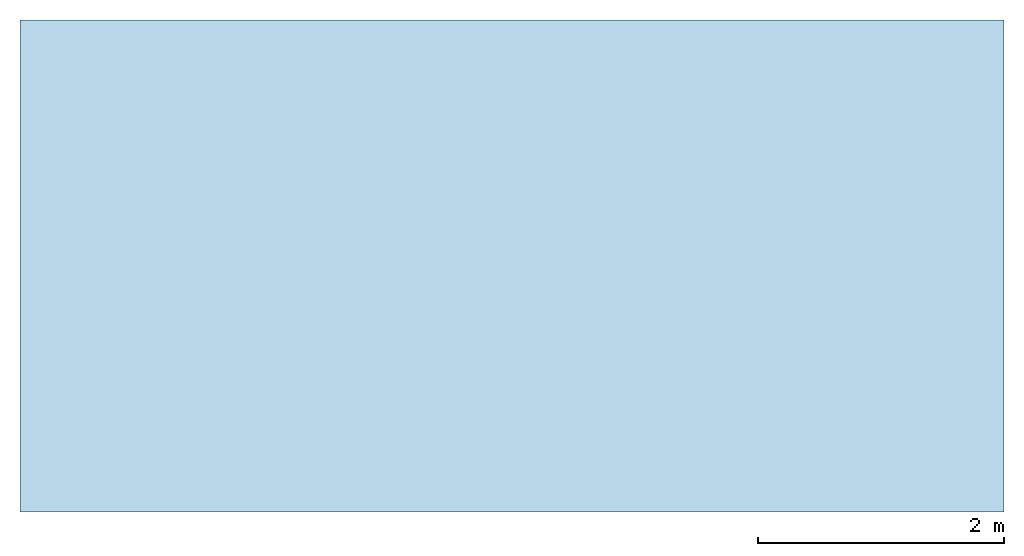
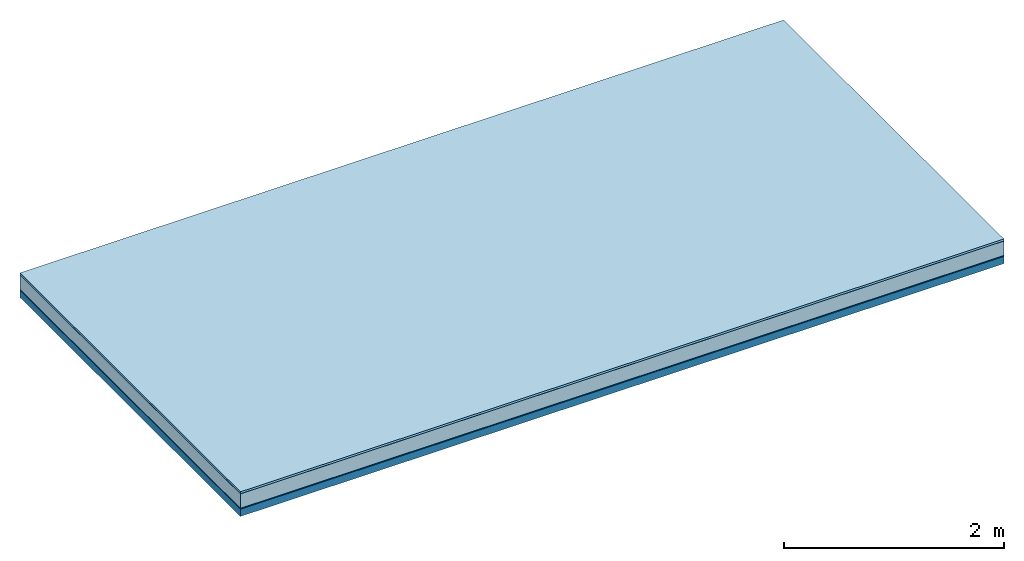
# One storey: 5 plates, 1 member, 1 element without a shape of its own.
"""IFC4 building model written with IfcOpenShell, lengths in metres."""

from ifc_helpers import new_model, si_unit, derived_unit, direction, frame, frame_2d, origin, origin_with_axes, place, context, project, spatial, rectangle, extrude, material, layer, layer_set, type_object, element, aggregate, save


model = new_model("IFC4")

# Units and contexts
plan_context = context("Plan", 3, precision=1e-05, world=origin(), true_north=direction((0.0, 1.0)))
model_context = context("Model", 3, precision=1e-05, world=origin(), true_north=direction((0.0, 1.0)))
ifc_project = project(units=[si_unit("LENGTHUNIT", "METRE"), derived_unit("SOUNDPRESSUREUNIT", [(si_unit("PRESSUREUNIT", "PASCAL", prefix="MICRO"), 0)]), si_unit("ENERGYUNIT", "JOULE", prefix="MEGA"), si_unit("MASSUNIT", "GRAM", prefix="KILO"), derived_unit("THERMALTRANSMITTANCEUNIT", [(si_unit("POWERUNIT", "WATT"), 1), (si_unit("AREAUNIT", "SQUARE_METRE"), -1), (si_unit("THERMODYNAMICTEMPERATUREUNIT", "KELVIN"), -1)]), derived_unit("AREADENSITYUNIT", [(si_unit("MASSUNIT", "GRAM", prefix="KILO"), 1), (si_unit("AREAUNIT", "SQUARE_METRE"), -1)]), derived_unit("USERDEFINED", [(si_unit("ENERGYUNIT", "JOULE", prefix="MEGA"), 1), (si_unit("AREAUNIT", "SQUARE_METRE"), -1)])], contexts=[plan_context, model_context])

# Site, building, storey
site = spatial("IfcSite", under=ifc_project)
building_placement = place(None, origin())
building = spatial("IfcBuilding", under=site, at=building_placement)
storey_placement = place(building_placement, origin())
storey = spatial("IfcBuildingStorey", under=building, at=storey_placement)

# Slab, member, plates
ifc_material_1 = material(Name="with tongue and groove", Category="07.009")
ifc_layer_1 = layer(ifc_material_1, 0.022, Name="Flooring")
ifc_material_2 = material(Category="09.006")
ifc_layer_2 = layer(ifc_material_2, 0.0005, Name="layer")
ifc_material_3 = material(Name="2x 60x80mm")
ifc_layer_3 = layer(ifc_material_3, 0.16, Name="On-material")
ifc_material_4 = material(Name="Wood fiber generic product", Category="10.009")
ifc_layer_4 = layer(ifc_material_4, 0.01, Name="Impact sound insulation")
ifc_material_5 = material(Name="protection", Category="09.007")
ifc_layer_5 = layer(ifc_material_5, 0.0005, Name="Sub-floor")
ifc_material_6 = material(Name="no composite action")
ifc_layer_6 = layer(ifc_material_6, 0.0, Name="Bond")
ifc_layer_7 = layer(None, 0.08, Name="Supporting structure")
ifc_layer_set = layer_set([ifc_layer_1, ifc_layer_2, ifc_layer_3, ifc_layer_4, ifc_layer_5, ifc_layer_6, ifc_layer_7])
slab_type = type_object("IfcSlabType", Name="A2022", PredefinedType="NOTDEFINED", material=ifc_layer_set)
slab_placement = place(None, frame((0.0, 0.0, 0.0), z_axis=(0.0, 0.0, -1.0), x_axis=(1.0, 0.0, 0.0)))
slab = element("IfcSlab", 1, at=slab_placement, inside=storey, type_object=slab_type, material=ifc_layer_set, Name="Slab #1")
ifc_material_7 = material(Name="Solid timber panel")
member_placement = place(slab_placement, origin())
member = element("IfcMember", 2, at=member_placement, material=ifc_material_7, Name="Supporting structure", context=plan_context, shape_type="SweptSolid", body=[
    extrude(rectangle(XDim=1.0, YDim=0.08, at=frame_2d((0.5, 0.04), x_axis=(1.0, 0.0))), frame((0.0, 4.0, 0.193), z_axis=(0.0, -1.0, 0.0), x_axis=(1.0, 0.0, 0.0)), (0.0, 0.0, 1.0), 4.0),
    extrude(rectangle(XDim=1.0, YDim=0.08, at=frame_2d((0.5, 0.04), x_axis=(1.0, 0.0))), frame((1.0, 4.0, 0.193), z_axis=(0.0, -1.0, 0.0), x_axis=(1.0, 0.0, 0.0)), (0.0, 0.0, 1.0), 4.0),
    extrude(rectangle(XDim=1.0, YDim=0.08, at=frame_2d((0.5, 0.04), x_axis=(1.0, 0.0))), frame((2.0, 4.0, 0.193), z_axis=(0.0, -1.0, 0.0), x_axis=(1.0, 0.0, 0.0)), (0.0, 0.0, 1.0), 4.0),
    extrude(rectangle(XDim=1.0, YDim=0.08, at=frame_2d((0.5, 0.04), x_axis=(1.0, 0.0))), frame((3.0, 4.0, 0.193), z_axis=(0.0, -1.0, 0.0), x_axis=(1.0, 0.0, 0.0)), (0.0, 0.0, 1.0), 4.0),
    extrude(rectangle(XDim=1.0, YDim=0.08, at=frame_2d((0.5, 0.04), x_axis=(1.0, 0.0))), frame((4.0, 4.0, 0.193), z_axis=(0.0, -1.0, 0.0), x_axis=(1.0, 0.0, 0.0)), (0.0, 0.0, 1.0), 4.0),
    extrude(rectangle(XDim=1.0, YDim=0.08, at=frame_2d((0.5, 0.04), x_axis=(1.0, 0.0))), frame((5.0, 4.0, 0.193), z_axis=(0.0, -1.0, 0.0), x_axis=(1.0, 0.0, 0.0)), (0.0, 0.0, 1.0), 4.0),
    extrude(rectangle(XDim=1.0, YDim=0.08, at=frame_2d((0.5, 0.04), x_axis=(1.0, 0.0))), frame((6.0, 4.0, 0.193), z_axis=(0.0, -1.0, 0.0), x_axis=(1.0, 0.0, 0.0)), (0.0, 0.0, 1.0), 4.0),
    extrude(rectangle(XDim=1.0, YDim=0.08, at=frame_2d((0.5, 0.04), x_axis=(1.0, 0.0))), frame((7.0, 4.0, 0.193), z_axis=(0.0, -1.0, 0.0), x_axis=(1.0, 0.0, 0.0)), (0.0, 0.0, 1.0), 4.0),
])
plate_1_placement = place(slab_placement, origin())
plate_1 = element("IfcPlate", 3, at=plate_1_placement, material=ifc_material_1, Name="Flooring", context=plan_context, shape_type="SweptSolid", body=[
    extrude(rectangle(XDim=8.0, YDim=4.0, at=frame_2d((4.0, 2.0), x_axis=(1.0, 0.0))), origin_with_axes(), (0.0, 0.0, 1.0), 0.022),
])
plate_2_placement = place(slab_placement, origin())
plate_2 = element("IfcPlate", 4, at=plate_2_placement, material=ifc_material_2, Name="layer", context=plan_context, shape_type="SweptSolid", body=[
    extrude(rectangle(XDim=8.0, YDim=4.0, at=frame_2d((4.0, 2.0), x_axis=(1.0, 0.0))), frame((0.0, 0.0, 0.022), z_axis=(0.0, 0.0, 1.0), x_axis=(1.0, 0.0, 0.0)), (0.0, 0.0, 1.0), 0.0005),
])
plate_3_placement = place(slab_placement, origin())
plate_3 = element("IfcPlate", 5, at=plate_3_placement, material=ifc_material_3, Name="On-material", context=plan_context, shape_type="SweptSolid", body=[
    extrude(rectangle(XDim=8.0, YDim=4.0, at=frame_2d((4.0, 2.0), x_axis=(1.0, 0.0))), frame((0.0, 0.0, 0.0225), z_axis=(0.0, 0.0, 1.0), x_axis=(1.0, 0.0, 0.0)), (0.0, 0.0, 1.0), 0.16),
])
plate_4_placement = place(slab_placement, origin())
plate_4 = element("IfcPlate", 6, at=plate_4_placement, material=ifc_material_4, Name="Impact sound insulation", context=plan_context, shape_type="SweptSolid", body=[
    extrude(rectangle(XDim=8.0, YDim=4.0, at=frame_2d((4.0, 2.0), x_axis=(1.0, 0.0))), frame((0.0, 0.0, 0.1825), z_axis=(0.0, 0.0, 1.0), x_axis=(1.0, 0.0, 0.0)), (0.0, 0.0, 1.0), 0.01),
])
plate_5_placement = place(slab_placement, origin())
plate_5 = element("IfcPlate", 7, at=plate_5_placement, material=ifc_material_5, Name="Sub-floor", context=plan_context, shape_type="SweptSolid", body=[
    extrude(rectangle(XDim=8.0, YDim=4.0, at=frame_2d((4.0, 2.0), x_axis=(1.0, 0.0))), frame((0.0, 0.0, 0.1925), z_axis=(0.0, 0.0, 1.0), x_axis=(1.0, 0.0, 0.0)), (0.0, 0.0, 1.0), 0.0005),
])
aggregate(slab, [plate_1, plate_2, plate_3, plate_4, plate_5, member])

save(model, "model.ifc")
